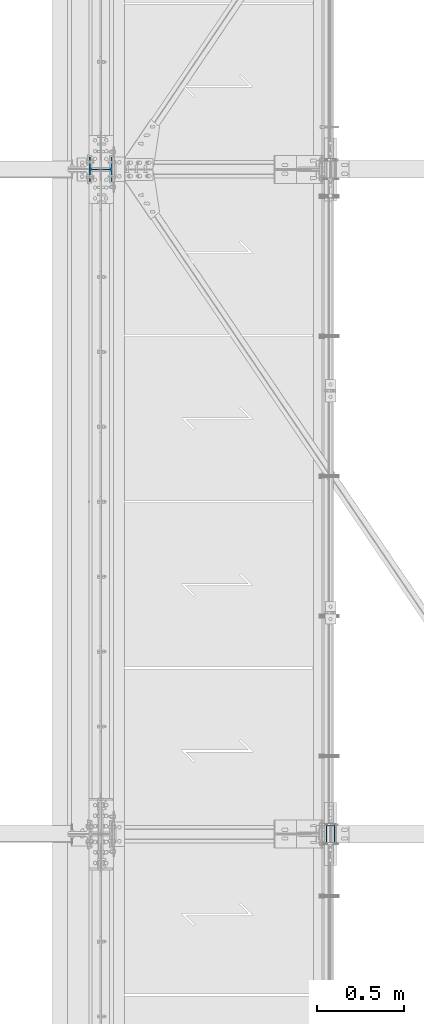
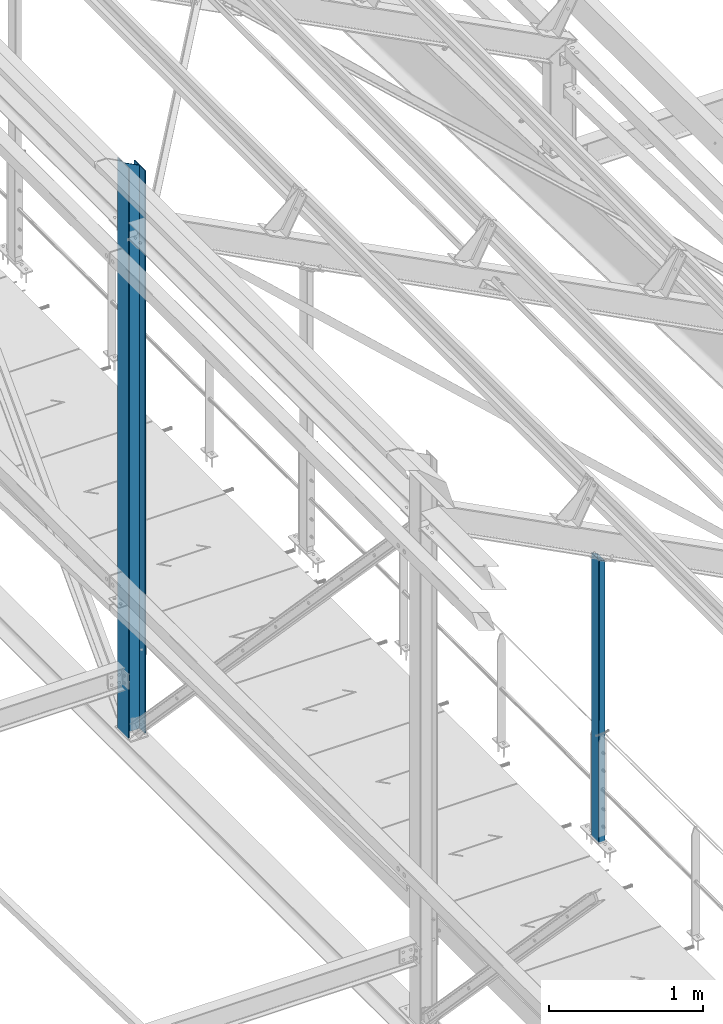
# One storey, part 11 of 496: 2 columns, 2 elements without a shape of their own.
"""IFC2X3 building model written with IfcOpenShell, lengths in millimetres."""

from ifc_helpers import new_model, si_unit, frame, origin_with_axes, origin_2d_with_axis, place, context, subcontext, project, spatial, hollow_rectangle, i_section, extrude, clip, halfspace, material, type_object, element, aggregate, save


model = new_model("IFC2X3")

# Units and contexts
model_context = context("Model", 3, precision=1e-05, world=origin_with_axes())
body_context = subcontext(model_context, "Body", "Model", "MODEL_VIEW")
ifc_project = project(units=[si_unit("LENGTHUNIT", "METRE", prefix="MILLI"), si_unit("AREAUNIT", "SQUARE_METRE"), si_unit("VOLUMEUNIT", "CUBIC_METRE"), si_unit("MASSUNIT", "GRAM", prefix="KILO"), si_unit("TIMEUNIT", "SECOND"), si_unit("PLANEANGLEUNIT", "RADIAN"), si_unit("SOLIDANGLEUNIT", "STERADIAN"), si_unit("THERMODYNAMICTEMPERATUREUNIT", "DEGREE_CELSIUS"), si_unit("LUMINOUSINTENSITYUNIT", "LUMEN")], contexts=[model_context])

# Site, building, storey
site_placement = place(None, origin_with_axes())
site = spatial("IfcSite", under=ifc_project, at=site_placement, CompositionType="ELEMENT")
building_placement = place(site_placement, origin_with_axes())
building = spatial("IfcBuilding", under=site, at=building_placement, Name="Undefined", CompositionType="ELEMENT")
storey_placement = place(building_placement, origin_with_axes())
storey = spatial("IfcBuildingStorey", under=building, at=storey_placement, Name="Undefined", CompositionType="ELEMENT", Elevation=0.0)

# Assembly, column
assembly_1_placement = place(storey_placement, origin_with_axes())
assembly_1 = element("IfcElementAssembly", 1, at=assembly_1_placement, inside=storey, Name="MONTANT", AssemblyPlace="NOTDEFINED", PredefinedType="NOTDEFINED")
ifc_material_1 = material(Name="Undefined/S275-E28")
column_type_1 = type_object("IfcColumnType", Name="HEA140", PredefinedType="NOTDEFINED")
column_1_placement = place(assembly_1_placement, frame((23470.0, 7600.0, 7260.0), z_axis=(0.0, 0.0, 1.0), x_axis=(-1.0, 0.0, 0.0)))
column_1 = element("IfcColumn", 2, at=column_1_placement, type_object=column_type_1, material=ifc_material_1, Name="MONTANT", ObjectType="HEA140", context=body_context, shape_type="Clipping", body=[
    clip(extrude(i_section(OverallWidth=140.0, OverallDepth=133.0, WebThickness=5.5, FlangeThickness=8.5, FilletRadius=12.0, at=origin_2d_with_axis()), frame((0.0, 0.0, 4551.40988027575), z_axis=(0.0, 0.0, -1.0), x_axis=(0.0, 1.0, 0.0)), (0.0, 0.0, 1.0), 4551.41), halfspace(frame((-66.5, 70.0, 4471.22657322575), z_axis=(-0.460093242228747, -7.1029704621934e-09, 0.887870603441425), x_axis=(0.887870603441425, 0.0, 0.460093242228747)), False)),
])
aggregate(assembly_1, [column_1])

assembly_2_placement = place(storey_placement, origin_with_axes())
assembly_2 = element("IfcElementAssembly", 3, at=assembly_2_placement, inside=storey, AssemblyPlace="NOTDEFINED", PredefinedType="NOTDEFINED")
ifc_material_2 = material(Name="Undefined/S235-E24")
column_type_2 = type_object("IfcColumnType", PredefinedType="NOTDEFINED")
column_2_placement = place(assembly_2_placement, frame((24783.9916006456, 3800.00010621387, 8249.99999999944), z_axis=(0.0, 0.0, 1.0), x_axis=(0.0, -1.0, 0.0)))
column_2 = element("IfcColumn", 4, at=column_2_placement, type_object=column_type_2, material=ifc_material_2, context=body_context, shape_type="Clipping", body=[
    clip(extrude(hollow_rectangle(XDim=50.0, YDim=100.0, WallThickness=3.0, InnerFilletRadius=3.0, OuterFilletRadius=6.0, at=origin_2d_with_axis()), frame((0.0, 0.0, 2250.9289509388), z_axis=(0.0, 0.0, -1.0), x_axis=(0.0, 1.0, 0.0)), (0.0, 0.0, 1.0), 2250.93), halfspace(frame((-1.97960616787896e-07, -50.6315018323185, 2264.08160073347), z_axis=(4.17299179827202e-08, -0.460093241031933, -0.887870604061611), x_axis=(1.0, 0.0, 0.0)), True)),
])
aggregate(assembly_2, [column_2])

save(model, "model.ifc")
